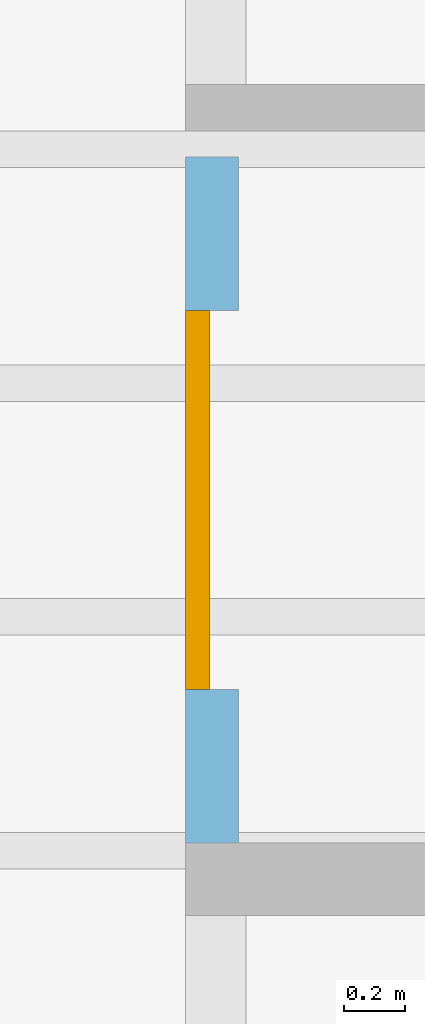
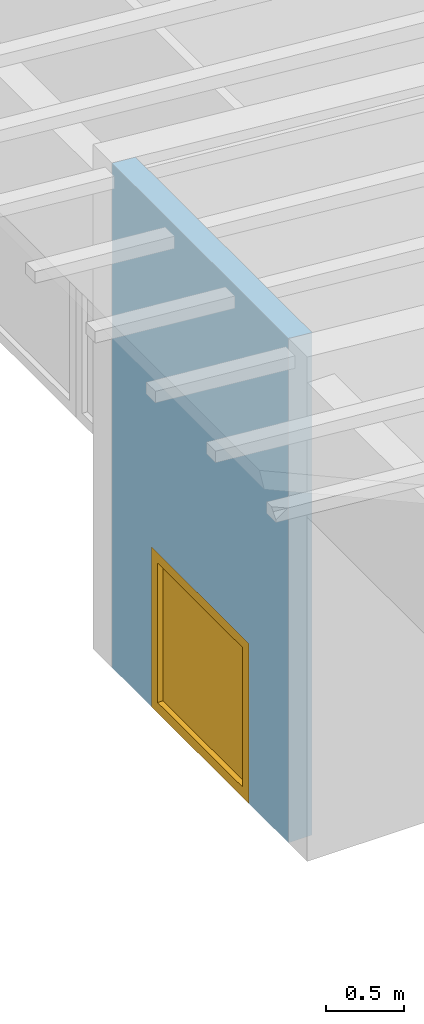
# One storey, part 7 of 13: 1 window, 1 opening, plus 1 element that does not belong to this part.
"""IFC2X3 building model written with IfcOpenShell, lengths in millimetres."""

from ifc_helpers import new_model, entity, si_unit, converted_unit, frame, frame_2d, origin, origin_with_axes, place, context, project, spatial, rectangle, extrude, clip, halfspace, faceted_brep, material, layer, layer_set, layer_usage, element, fill, save


model = new_model("IFC2X3")

# Units and contexts
model_context = context("Model", 3, precision=1e-05, world=origin())
plan_context = context("Plan", 3, precision=1e-05, world=origin())
ifc_project = project(units=[si_unit("LENGTHUNIT", "METRE", prefix="MILLI"), converted_unit("PLANEANGLEUNIT", "DEGREE", entity("IfcPlaneAngleMeasure", 0.0174532925199433), si_unit("PLANEANGLEUNIT", "RADIAN"), dimensions=[0, 0, 0, 0, 0, 0, 0]), si_unit("AREAUNIT", "SQUARE_METRE"), si_unit("VOLUMEUNIT", "CUBIC_METRE")], contexts=[model_context, plan_context])

# Building, storey
building_placement = place(None, origin())
building = spatial("IfcBuilding", under=ifc_project, at=building_placement, CompositionType="ELEMENT")
storey_placement = place(building_placement, frame((0.0, 0.0, 4770.0), z_axis=(0.0, 0.0, 1.0), x_axis=(1.0, 0.0, 0.0)))
storey = spatial("IfcBuildingStorey", under=building, at=storey_placement, Name="Geschoss", CompositionType="ELEMENT", Elevation=4770.0)

# Wall, opening, window
ifc_material_1 = material()
ifc_layer = layer(ifc_material_1, 175.0)
ifc_layer_set = layer_set([ifc_layer])
ifc_layer_usage = layer_usage(ifc_layer_set, "AXIS2", "POSITIVE", 0.0)
wall_placement = place(storey_placement, frame((21188.3517822139, 1688.4375, 0.0), z_axis=(0.0, 0.0, 1.0), x_axis=(-1.64835853914244e-12, -1.0, 0.0)))
wall = element("IfcWallStandardCase", 1, at=wall_placement, inside=storey, material=ifc_layer_usage, context=model_context, shape_type="Clipping", body=[
    clip(extrude(rectangle(XDim=2260.0, YDim=175.0, at=frame_2d((1130.0, 87.5), x_axis=(1.0, 0.0))), origin_with_axes(), (0.0, 0.0, 1.0), 3940.60829407437), halfspace(frame((7.44497875345265e-14, 175.0, 3925.29777795701), z_axis=(1.43522023988273e-13, -0.0871557427476597, -0.996194698091745), x_axis=(1.0, 0.0, 0.0)), True)),
])
opening_placement = place(wall_placement, frame((505.000000000001, -8.54925019665361e-13, 0.0), z_axis=(0.0, 1.0, 0.0), x_axis=(0.0, 0.0, 1.0)))
opening = element("IfcOpeningElement", 2, at=opening_placement, cuts=wall, ObjectType="Opening", context=model_context, shape_type="SweptSolid", body=[
    extrude(rectangle(XDim=1250.0, YDim=1250.0, at=frame_2d((625.0, 625.0), x_axis=(1.0, 0.0))), origin_with_axes(), (0.0, 0.0, 1.0), 175.0),
])
ifc_material_2 = material()
window_placement = place(opening_placement, frame((0.0, 0.0, 0.0), z_axis=(1.0, 0.0, 0.0), x_axis=(0.0, 1.0, 0.0)))
window = element("IfcWindow", 3, at=window_placement, inside=storey, material=ifc_material_2, Name="m", OverallHeight=1250.0, OverallWidth=1250.0, context=model_context, shape_type="Brep", body=[
    faceted_brep([(79.9999999997119, -8.9765050947932e-10, 0.0), (-2.88082446786575e-10, -1.02951436264931e-09, 0.0), (-2.88082446786575e-10, -1.02951436264931e-09, 1250.0), (79.9999999997119, -8.9765050947932e-10, 1250.0), (-4.1995917854365e-10, 79.9999999989705, 0.0), (79.99999999958, 79.9999999991024, 0.0), (79.99999999958, 79.9999999991024, 1250.0), (-4.1995917854365e-10, 79.9999999989705, 1250.0), (-2.88082446786575e-10, -1.02951436264931e-09, 0.0), (79.9999999997119, -8.9765050947932e-10, 0.0), (79.99999999958, 79.9999999991024, 0.0), (-4.1995917854365e-10, 79.9999999989705, 0.0), (-2.88082446786575e-10, -1.02951436264931e-09, 1250.0), (-2.88082446786575e-10, -1.02951436264931e-09, 0.0), (-4.1995917854365e-10, 79.9999999989705, 0.0), (-4.1995917854365e-10, 79.9999999989705, 1250.0), (79.9999999997119, -8.9765050947932e-10, 1250.0), (-2.88082446786575e-10, -1.02951436264931e-09, 1250.0), (-4.1995917854365e-10, 79.9999999989705, 1250.0), (79.99999999958, 79.9999999991024, 1250.0), (79.9999999997119, -8.9765050947932e-10, 0.0), (79.9999999997119, -8.9765050947932e-10, 1250.0), (79.99999999958, 79.9999999991024, 1250.0), (79.99999999958, 79.9999999991024, 0.0)], [[[0, 1, 2, 3]], [[4, 5, 6, 7]], [[8, 9, 10, 11]], [[12, 13, 14, 15]], [[16, 17, 18, 19]], [[20, 21, 22, 23]]], orient=[[False], [False], [False], [False], [False], [False]]),
    faceted_brep([(1170.00000000013, 8.98979335417494e-10, 1250.0), (1250.00000000013, 1.03084307756518e-09, 1250.0), (1250.00000000013, 1.03084307756518e-09, 0.0), (1170.00000000013, 8.98979335417494e-10, 0.0), (1250.0, 80.0000000010309, 1250.0), (1170.0, 80.000000000899, 1250.0), (1170.0, 80.000000000899, 0.0), (1250.0, 80.0000000010309, 0.0), (1250.00000000013, 1.03084307756518e-09, 1250.0), (1170.00000000013, 8.98979335417494e-10, 1250.0), (1170.0, 80.000000000899, 1250.0), (1250.0, 80.0000000010309, 1250.0), (1250.00000000013, 1.03084307756518e-09, 0.0), (1250.00000000013, 1.03084307756518e-09, 1250.0), (1250.0, 80.0000000010309, 1250.0), (1250.0, 80.0000000010309, 0.0), (1170.00000000013, 8.98979335417494e-10, 0.0), (1250.00000000013, 1.03084307756518e-09, 0.0), (1250.0, 80.0000000010309, 0.0), (1170.0, 80.000000000899, 0.0), (1170.00000000013, 8.98979335417494e-10, 1250.0), (1170.00000000013, 8.98979335417494e-10, 0.0), (1170.0, 80.000000000899, 0.0), (1170.0, 80.000000000899, 1250.0)], [[[0, 1, 2, 3]], [[4, 5, 6, 7]], [[8, 9, 10, 11]], [[12, 13, 14, 15]], [[16, 17, 18, 19]], [[20, 21, 22, 23]]], orient=[[False], [False], [False], [False], [False], [False]]),
    faceted_brep([(1170.00000000013, 8.98965124562778e-10, 80.0), (1170.00000000013, 8.98965124562778e-10, 0.0), (79.9999999997137, -8.9767893118875e-10, 0.0), (79.9999999997137, -8.9767893118875e-10, 80.0), (1170.0, 80.000000000899, 0.0), (1170.0, 80.000000000899, 80.0), (79.9999999995819, 79.9999999991023, 80.0), (79.9999999995819, 79.9999999991023, 0.0), (1170.00000000013, 8.98965124562778e-10, 0.0), (1170.00000000013, 8.98965124562778e-10, 80.0), (1170.0, 80.000000000899, 80.0), (1170.0, 80.000000000899, 0.0), (79.9999999997137, -8.9767893118875e-10, 0.0), (1170.00000000013, 8.98965124562778e-10, 0.0), (1170.0, 80.000000000899, 0.0), (79.9999999995819, 79.9999999991023, 0.0), (79.9999999997137, -8.9767893118875e-10, 80.0), (79.9999999997137, -8.9767893118875e-10, 0.0), (79.9999999995819, 79.9999999991023, 0.0), (79.9999999995819, 79.9999999991023, 80.0), (1170.00000000013, 8.98965124562778e-10, 80.0), (79.9999999997137, -8.9767893118875e-10, 80.0), (79.9999999995819, 79.9999999991023, 80.0), (1170.0, 80.000000000899, 80.0)], [[[0, 1, 2, 3]], [[4, 5, 6, 7]], [[8, 9, 10, 11]], [[12, 13, 14, 15]], [[16, 17, 18, 19]], [[20, 21, 22, 23]]], orient=[[False], [False], [False], [False], [False], [False]]),
    faceted_brep([(79.9999999997137, -8.9767893118875e-10, 1170.0), (79.9999999997137, -8.9767893118875e-10, 1250.0), (1170.00000000013, 8.98965124562778e-10, 1250.0), (1170.00000000013, 8.98965124562778e-10, 1170.0), (79.9999999995819, 79.9999999991023, 1250.0), (79.9999999995819, 79.9999999991023, 1170.0), (1170.0, 80.000000000899, 1170.0), (1170.0, 80.000000000899, 1250.0), (79.9999999997137, -8.9767893118875e-10, 1250.0), (79.9999999997137, -8.9767893118875e-10, 1170.0), (79.9999999995819, 79.9999999991023, 1170.0), (79.9999999995819, 79.9999999991023, 1250.0), (1170.00000000013, 8.98965124562778e-10, 1250.0), (79.9999999997137, -8.9767893118875e-10, 1250.0), (79.9999999995819, 79.9999999991023, 1250.0), (1170.0, 80.000000000899, 1250.0), (1170.00000000013, 8.98965124562778e-10, 1170.0), (1170.00000000013, 8.98965124562778e-10, 1250.0), (1170.0, 80.000000000899, 1250.0), (1170.0, 80.000000000899, 1170.0), (79.9999999997137, -8.9767893118875e-10, 1170.0), (1170.00000000013, 8.98965124562778e-10, 1170.0), (1170.0, 80.000000000899, 1170.0), (79.9999999995819, 79.9999999991023, 1170.0)], [[[0, 1, 2, 3]], [[4, 5, 6, 7]], [[8, 9, 10, 11]], [[12, 13, 14, 15]], [[16, 17, 18, 19]], [[20, 21, 22, 23]]], orient=[[False], [False], [False], [False], [False], [False]]),
    faceted_brep([(1170.00000000007, 40.000000000899, 1170.0), (1170.00000000007, 40.000000000899, 80.0), (79.9999999996455, 39.9999999991023, 80.0), (79.9999999996455, 39.9999999991023, 1170.0), (1170.00000000006, 41.000000000899, 1170.0), (79.9999999996439, 40.9999999991023, 1170.0), (79.9999999996439, 40.9999999991023, 80.0), (1170.00000000006, 41.000000000899, 80.0), (1170.00000000007, 40.000000000899, 1170.0), (1170.00000000006, 41.000000000899, 1170.0), (1170.00000000006, 41.000000000899, 80.0), (1170.00000000007, 40.000000000899, 80.0), (1170.00000000007, 40.000000000899, 80.0), (1170.00000000006, 41.000000000899, 80.0), (79.9999999996439, 40.9999999991023, 80.0), (79.9999999996455, 39.9999999991023, 80.0), (79.9999999996455, 39.9999999991023, 80.0), (79.9999999996439, 40.9999999991023, 80.0), (79.9999999996439, 40.9999999991023, 1170.0), (79.9999999996455, 39.9999999991023, 1170.0), (79.9999999996455, 39.9999999991023, 1170.0), (79.9999999996439, 40.9999999991023, 1170.0), (1170.00000000006, 41.000000000899, 1170.0), (1170.00000000007, 40.000000000899, 1170.0)], [[[0, 1, 2, 3]], [[4, 5, 6, 7]], [[8, 9, 10, 11]], [[12, 13, 14, 15]], [[16, 17, 18, 19]], [[20, 21, 22, 23]]], orient=[[False], [False], [False], [False], [False], [False]]),
])
fill(opening, window)

save(model, "model.ifc")
